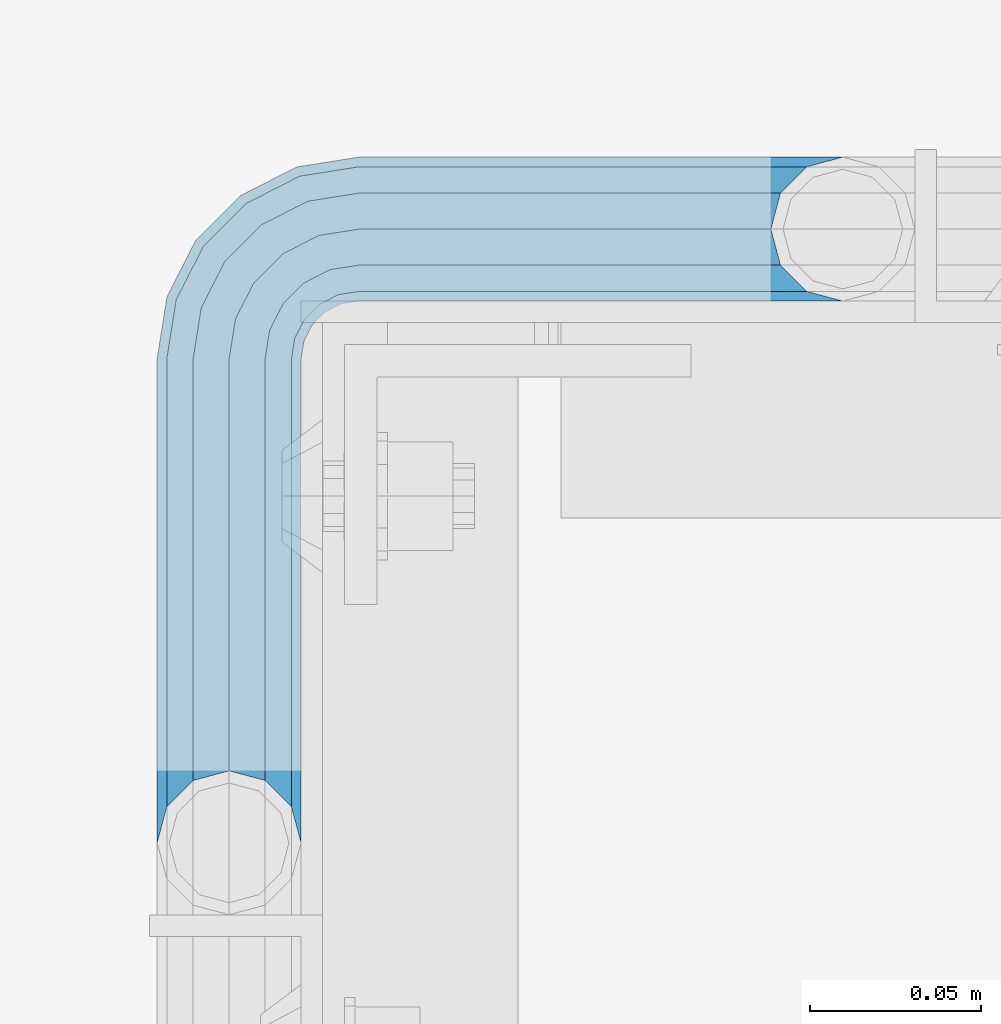
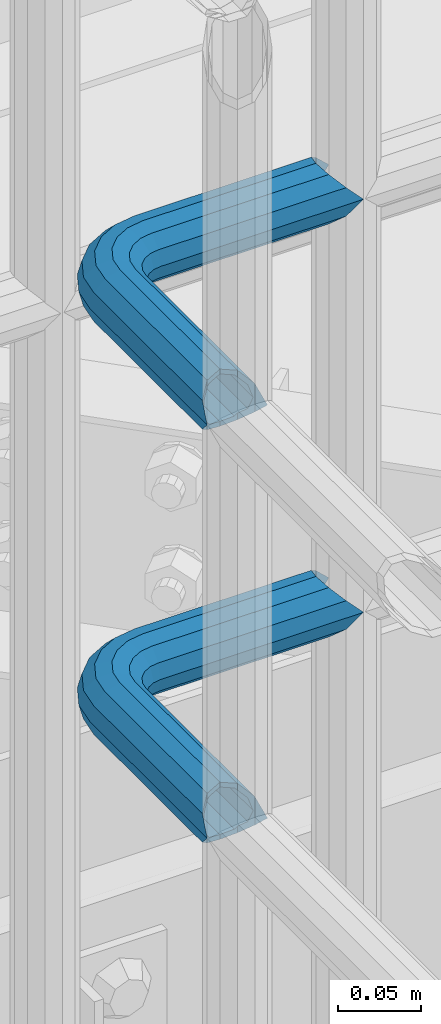
# One storey, part 1109 of 1876: 2 beams, 1 element without a shape of its own.
"""IFC2X3 building model written with IfcOpenShell, lengths in millimetres."""

from ifc_helpers import new_model, si_unit, frame, origin_with_axes, place, context, subcontext, project, spatial, faceted_brep, material, type_object, element, aggregate, save


model = new_model("IFC2X3")

# Units and contexts
model_context = context("Model", 3, precision=1e-05, world=origin_with_axes())
body_context = subcontext(model_context, "Body", "Model", "MODEL_VIEW")
ifc_project = project(units=[si_unit("LENGTHUNIT", "METRE", prefix="MILLI"), si_unit("AREAUNIT", "SQUARE_METRE"), si_unit("VOLUMEUNIT", "CUBIC_METRE"), si_unit("MASSUNIT", "GRAM", prefix="KILO"), si_unit("TIMEUNIT", "SECOND"), si_unit("PLANEANGLEUNIT", "RADIAN"), si_unit("SOLIDANGLEUNIT", "STERADIAN"), si_unit("THERMODYNAMICTEMPERATUREUNIT", "DEGREE_CELSIUS"), si_unit("LUMINOUSINTENSITYUNIT", "LUMEN")], contexts=[model_context])

# Site, building, storey
site_placement = place(None, origin_with_axes())
site = spatial("IfcSite", under=ifc_project, at=site_placement, CompositionType="ELEMENT")
building_placement = place(site_placement, origin_with_axes())
building = spatial("IfcBuilding", under=site, at=building_placement, Name="Undefined", CompositionType="ELEMENT")
storey_placement = place(building_placement, origin_with_axes())
storey = spatial("IfcBuildingStorey", under=building, at=storey_placement, Name="Undefined", CompositionType="ELEMENT", Elevation=0.0)

# Assembly, beams
assembly_placement = place(storey_placement, origin_with_axes())
assembly = element("IfcElementAssembly", 1, at=assembly_placement, inside=storey, Name="HANDRAIL", AssemblyPlace="NOTDEFINED", PredefinedType="RIGID_FRAME")
ifc_material = material()
beam_type = type_object("IfcBeamType", Name="PIPE1-1/4STD", PredefinedType="NOTDEFINED")
beam_1_placement = place(assembly_placement, frame((3517.90143150121, -11745.4324531238, 8480.425), z_axis=(0.0, 0.0, -1.0), x_axis=(-1.0, 0.0, 0.0)))
beam_1 = element("IfcBeam", 2, at=beam_1_placement, type_object=beam_type, material=ifc_material, Name="HANDRAIL", ObjectType="PIPE1-1/4STD", context=body_context, shape_type="Brep", body=[
    faceted_brep([(9.09494701772928e-13, 21.0820000000003, 0.0), (10.5409999957128, 18.2575475579433, -10.5409999999993), (10.5409999999983, 18.2575475625836, 10.5410000000011), (10.5409999999983, -18.2575475625836, 10.5410000000011), (10.5409999957128, -18.2575475672238, -10.5409999999993), (9.09494701772928e-13, -21.0820000000003, 0.0), (18.2575475625817, -10.5410000000011, 18.2575475625836), (18.2575475625817, -10.5409999999974, 13.3999612267289), (13.6205863358537, -15.1779612267255, 8.76300000000083), (11.2725475625793, -17.5259999999998, 0.0), (13.6205863358537, -15.1779612267255, -8.76299999999901), (18.2575475625817, -10.5409999999974, -13.3999612267271), (18.2575475625817, -10.5410000000011, -18.2575475625836), (21.0819999999985, 0.0, -17.5259999999998), (21.0819999999985, 0.0, -21.0819999999985), (18.7339612267233, -8.76300000000083, -15.1779612267255), (18.7339612267251, 8.76299999999901, -15.1779612267255), (18.2575475625817, 10.5410000000011, -13.3999612267235), (18.2575475625817, 10.5409999999993, -18.2575475625836), (13.6205863358573, 15.1779612267255, -8.76299999999901), (11.2725475625839, 17.5259999999998, 0.0), (13.6205863358573, 15.1779612267255, 8.76300000000083), (18.2575475625817, 10.5410000000011, 13.3999612267253), (18.2575475625817, 10.5409999999993, 18.2575475625836), (18.7339612267251, 8.76299999999901, 15.1779612267273), (21.0819999999985, 1.81898940354586e-12, 17.5259999999998), (21.0819999999985, 1.81898940354586e-12, 21.0820000000003), (18.7339612267233, -8.76300000000083, 15.1779612267273), (141.7320022583, -8.7629999999981, 15.1779612267255), (141.7320022583, 1.81898940354586e-12, 17.525999999998), (153.505549272468, -1.86474665447258, 17.525999999998), (150.797633350759, -10.1988549067664, 15.1779612267237), (141.7320022583, -15.1779612267246, 8.76299999999901), (148.815301313444, -16.2998455832249, 8.76299999999901), (141.732002258301, -17.5259999999989, -1.81898940354586e-12), (148.08971742905, -18.5329631590612, -1.81898940354586e-12), (141.7320022583, -15.1779612267246, -8.76300000000083), (148.815301313443, -16.2998455832249, -8.76300000000083), (141.7320022583, -8.76299999999901, -15.1779612267273), (150.797633350759, -10.1988549067664, -15.1779612267273), (141.7320022583, 1.81898940354586e-12, -17.5260000000017), (153.505549272467, -1.86474665447258, -17.5260000000017), (141.7320022583, 8.76300000000174, -15.1779612267273), (156.213465194176, 6.46936159782217, -15.1779612267273), (141.7320022583, 15.1779612267273, -8.76300000000083), (158.195797231491, 12.5703522742806, -8.76300000000083), (141.7320022583, 17.5260000000017, -1.81898940354586e-12), (158.921381115884, 14.803469850116, -1.81898940354586e-12), (141.7320022583, 15.1779612267273, 8.76299999999901), (158.195797231491, 12.5703522742806, 8.76299999999901), (141.7320022583, 8.76300000000174, 15.1779612267255), (156.213465194176, 6.46936159782217, 15.1779612267237), (179.832000732422, -38.0999984741202, -17.5260000000017), (171.069000732422, -38.0999984741202, -15.1779612267273), (171.069000732422, -161.097989750122, -15.1779612267255), (179.832000732422, -158.7499511731, -17.5259999999998), (188.595000732423, -38.0999984741202, -15.1779612267273), (188.595000732422, -161.097990142627, -15.1779612267255), (169.291000732422, -38.0999984741202, -18.2575475625854), (179.832000732422, -38.0999984741202, -21.0820000000003), (179.832000732422, -158.7499511731, -21.0820000000003), (169.291000732422, -161.574403610517, -18.2575475625836), (161.574453169838, -38.0999984741193, -10.5410000000011), (161.574453169838, -169.2909511731, -10.5409999999993), (158.750000732422, -38.0999984741193, -1.81898940354586e-12), (158.750000732422, -179.831954956055, 0.0), (161.574453169838, -169.2909511731, 10.5409999999993), (161.574453169839, -38.0999984741193, 10.5409999999993), (169.291000732423, -38.0999984741193, 18.2575475625817), (169.291000732422, -161.574403610517, 18.2575475625836), (179.832000732423, -38.0999984741193, 21.0819999999985), (179.832000732422, -158.7499511731, 21.0820000000003), (141.7320022583, 10.5410000000011, 18.2575475625817), (141.7320022583, 18.2575475625854, 10.5409999999993), (141.7320022583, 21.0820000000012, -1.81898940354586e-12), (141.7320022583, 18.2575475625854, -10.5410000000011), (141.7320022583, 10.5410000000011, -18.2575475625854), (141.7320022583, 1.81898940354586e-12, -21.0820000000022), (141.7320022583, -10.5409999999983, -18.2575475625854), (141.7320022583, -18.2575475625817, -10.5410000000011), (141.732002258301, -21.0819999999985, -1.81898940354586e-12), (141.7320022583, -18.2575475625817, 10.5409999999993), (141.7320022583, -10.5409999999983, 18.2575475625817), (141.7320022583, 1.81898940354586e-12, 21.0819999999985), (153.505549272468, -1.86474665447258, 21.0819999999985), (156.762897410175, 8.16034008379484, 18.2575475625817), (159.147441744916, 15.4992129264911, 10.5409999999993), (160.020245547882, 18.1854268220623, -1.81898940354586e-12), (159.147441744916, 15.4992129264911, -10.5410000000011), (156.762897410174, 8.16034008379484, -18.2575475625854), (153.505549272467, -1.86474665447258, -21.0820000000022), (150.24820113476, -11.8898333927391, -18.2575475625854), (147.863656800018, -19.2287062354353, -10.5410000000011), (146.990852997053, -21.9149201310065, -1.81898940354586e-12), (147.863656800019, -19.2287062354362, 10.5409999999993), (150.248201134761, -11.8898333927391, 18.2575475625817), (157.930775129339, -15.8043003606008, 18.2575475625817), (164.126619473753, -7.27645222289357, 21.0819999999985), (153.395102273439, -22.0471184766338, 10.5409999999993), (151.734930784924, -24.332148498308, -1.81898940354586e-12), (153.395102273439, -22.0471184766338, -10.5410000000011), (157.930775129338, -15.8043003606008, -18.2575475625854), (164.126619473752, -7.27645222289357, -21.0820000000022), (170.322463818167, 1.25139591481275, -18.2575475625854), (174.858136674066, 7.49421403084671, -10.5410000000011), (176.518308162581, 9.77924405251997, -1.81898940354586e-12), (174.858136674067, 7.49421403084671, 10.5409999999993), (170.322463818167, 1.25139591481275, 18.2575475625817), (172.555548509522, -15.7053812586619, 21.0819999999985), (181.083396647228, -9.50953691424547, 18.2575475625817), (164.027700371817, -21.9012256030774, 18.2575475625817), (157.784882255784, -26.4368984589782, 10.5409999999993), (155.499852234111, -28.0970699474938, -1.81898940354586e-12), (157.784882255784, -26.4368984589782, -10.5410000000011), (164.027700371817, -21.9012256030774, -18.2575475625854), (172.555548509522, -15.7053812586619, -21.0820000000022), (181.083396647228, -9.50953691424547, -18.2575475625854), (187.32621476326, -4.97386405834459, -10.5410000000011), (189.611244784934, -3.31369256982998, -1.81898940354586e-12), (187.32621476326, -4.97386405834459, 10.5409999999993), (187.992340816218, -23.0691033222502, 18.2575475625817), (195.331213658914, -20.6845589875093, 10.5409999999993), (177.96725407795, -26.3264514599559, 21.0819999999985), (167.942167339683, -29.5837995976626, 18.2575475625817), (160.603294496986, -31.9683439324035, 10.5409999999993), (157.917080601415, -32.8411477353693, -1.81898940354586e-12), (160.603294496986, -31.9683439324035, -10.5410000000011), (167.942167339682, -29.5837995976635, -18.2575475625854), (177.96725407795, -26.3264514599568, -21.0820000000022), (187.992340816217, -23.0691033222511, -18.2575475625854), (195.331213658914, -20.6845589875093, -10.5410000000011), (198.017427554485, -19.8117551845444, -1.81898940354586e-12), (198.089548295007, -38.0999984741193, 10.5409999999993), (200.914000732423, -38.0999984741202, -1.81898940354586e-12), (190.373000732423, -38.0999984741193, 18.2575475625817), (190.373000732422, -38.0999984741202, -18.2575475625854), (198.089548295006, -38.0999984741202, -10.5410000000011), (200.913999999997, -179.831951173101, 0.0), (198.089548295005, -169.2909511731, -10.5409999999993), (190.373000732422, -161.574403610517, -18.2575475625836), (190.372999999998, -161.574403610517, -13.3999619591505), (169.290999999997, -161.574403610517, -13.3999604943019), (164.654039505696, -38.0999984741193, -8.76300000000083), (164.654039505696, -166.211364104819, -8.76300000000083), (162.306000732422, -38.0999984741193, -1.81898940354586e-12), (162.306000732422, -168.559402878092, 0.0), (164.654039505696, -166.211364104819, 8.76299999999901), (169.290999999997, -161.574403610517, 13.3999604943019), (164.654039505696, -38.0999984741193, 8.76299999999901), (171.069000732422, -38.0999984741193, 15.1779612267255), (171.069000732422, -161.097989750122, 15.1779612267255), (179.832000732422, -158.7499511731, 17.5259999999998), (179.832000732423, -38.0999984741193, 17.525999999998), (188.595000732423, -38.0999984741193, 15.1779612267255), (188.595000732422, -161.097990142627, 15.1779612267255), (197.358000732423, -38.0999984741202, -1.81898940354586e-12), (195.009961959149, -38.0999984741202, -8.76300000000083), (195.009961959148, -166.211365569668, -8.76300000000083), (197.358000732422, -168.559404342942, 0.0), (195.009961959149, -38.0999984741193, 8.76299999999901), (195.009961959148, -166.211365569668, 8.76299999999901), (190.372999999998, -161.574403610517, 13.3999619591505), (190.373000732422, -161.574403610517, 18.2575475625836), (198.089548295005, -169.2909511731, 10.5409999999993), (186.301362330245, -23.6185355382495, -15.1779612267273), (192.402353006703, -21.6362035009342, -8.76300000000083), (177.96725407795, -26.3264514599568, -17.5260000000017), (169.633145825655, -29.0343673816642, -15.1779612267273), (163.532155149196, -31.0166994189794, -8.76300000000083), (161.299037573361, -31.7422833033716, -1.81898940354586e-12), (163.532155149197, -31.0166994189785, 8.76299999999901), (169.633145825655, -29.0343673816642, 15.1779612267255), (177.96725407795, -26.3264514599568, 17.525999999998), (186.301362330245, -23.6185355382486, 15.1779612267255), (192.402353006703, -21.6362035009342, 8.76299999999901), (194.635470582539, -20.9106196165412, -1.81898940354586e-12), (184.834777081907, -6.78399948972401, -8.76300000000083), (186.734380352937, -5.40385692698237, -1.81898940354586e-12), (179.644964431229, -10.5546190928217, -15.1779612267273), (172.555548509522, -15.7053812586619, -17.5260000000017), (165.466132587815, -20.8561434245012, -15.1779612267273), (160.276319937137, -24.6267630275997, -8.76300000000083), (158.376716666108, -26.0069055903414, -1.81898940354586e-12), (160.276319937138, -24.6267630275997, 8.76299999999901), (165.466132587815, -20.8561434245012, 15.1779612267237), (172.555548509522, -15.7053812586619, 17.525999999998), (179.64496443123, -10.5546190928217, 15.1779612267237), (184.834777081907, -6.7839994897231, 8.76299999999901), (174.428143805429, 6.90237962052288, -1.81898940354586e-12), (173.048001242688, 5.00277634949271, 8.76299999999901), (173.048001242688, 5.00277634949271, -8.76300000000083), (169.277381639591, -0.187036301185799, -15.1779612267273), (164.126619473753, -7.27645222289357, -17.5260000000017), (158.975857307914, -14.3658681446022, -15.1779612267273), (155.205237704817, -19.5556807952798, -8.76300000000083), (153.825095142076, -21.45528406631, -1.81898940354586e-12), (155.205237704817, -19.5556807952798, 8.76299999999901), (158.975857307914, -14.3658681446022, 15.1779612267237), (164.126619473753, -7.27645222289357, 17.525999999998), (169.277381639591, -0.187036301185799, 15.1779612267237)], [[[0, 1, 2]], [[3, 4, 5]], [[6, 7, 8, 9, 10, 11, 12, 4, 3]], [[13, 14, 12, 11, 15]], [[16, 17, 18, 14, 13]], [[2, 1, 18, 17, 19, 20, 21, 22, 23]], [[23, 22, 24, 25, 26]], [[26, 25, 27, 7, 6]], [[28, 29, 30, 31]], [[32, 28, 31, 33]], [[34, 32, 33, 35]], [[36, 34, 35, 37]], [[38, 36, 37, 39]], [[40, 38, 39, 41]], [[42, 40, 41, 43]], [[44, 42, 43, 45]], [[46, 44, 45, 47]], [[48, 46, 47, 49]], [[50, 48, 49, 51]], [[52, 53, 54, 55]], [[56, 52, 55, 57]], [[58, 59, 60, 61]], [[62, 58, 61, 63]], [[64, 62, 63, 65]], [[65, 63, 66]], [[67, 64, 65, 66]], [[68, 67, 66, 69]], [[70, 68, 69, 71]], [[72, 73, 2, 23]], [[73, 74, 0, 2]], [[74, 75, 1, 0]], [[75, 76, 18, 1]], [[76, 77, 14, 18]], [[77, 78, 12, 14]], [[78, 79, 4, 12]], [[79, 80, 5, 4]], [[80, 81, 3, 5]], [[81, 82, 6, 3]], [[82, 83, 26, 6]], [[83, 72, 23, 26]], [[72, 83, 84, 85]], [[73, 72, 85, 86]], [[74, 73, 86, 87]], [[75, 74, 87, 88]], [[76, 75, 88, 89]], [[77, 76, 89, 90]], [[78, 77, 90, 91]], [[79, 78, 91, 92]], [[80, 79, 92, 93]], [[81, 80, 93, 94]], [[82, 81, 94, 95]], [[83, 82, 95, 84]], [[95, 96, 97, 84]], [[94, 98, 96, 95]], [[93, 99, 98, 94]], [[92, 100, 99, 93]], [[91, 101, 100, 92]], [[90, 102, 101, 91]], [[89, 103, 102, 90]], [[88, 104, 103, 89]], [[87, 105, 104, 88]], [[86, 106, 105, 87]], [[85, 107, 106, 86]], [[84, 97, 107, 85]], [[97, 108, 109, 107]], [[96, 110, 108, 97]], [[98, 111, 110, 96]], [[99, 112, 111, 98]], [[100, 113, 112, 99]], [[101, 114, 113, 100]], [[102, 115, 114, 101]], [[103, 116, 115, 102]], [[104, 117, 116, 103]], [[105, 118, 117, 104]], [[106, 119, 118, 105]], [[107, 109, 119, 106]], [[109, 120, 121, 119]], [[108, 122, 120, 109]], [[110, 123, 122, 108]], [[111, 124, 123, 110]], [[112, 125, 124, 111]], [[113, 126, 125, 112]], [[114, 127, 126, 113]], [[115, 128, 127, 114]], [[116, 129, 128, 115]], [[117, 130, 129, 116]], [[118, 131, 130, 117]], [[119, 121, 131, 118]], [[121, 132, 133, 131]], [[120, 134, 132, 121]], [[122, 70, 134, 120]], [[123, 68, 70, 122]], [[124, 67, 68, 123]], [[125, 64, 67, 124]], [[126, 62, 64, 125]], [[127, 58, 62, 126]], [[128, 59, 58, 127]], [[129, 135, 59, 128]], [[130, 136, 135, 129]], [[131, 133, 136, 130]], [[136, 133, 137, 138]], [[135, 136, 138, 139]], [[59, 135, 139, 60]], [[57, 55, 60, 139, 140]], [[54, 141, 61, 60, 55]], [[53, 142, 143, 141, 54]], [[142, 144, 145, 143]], [[66, 63, 61, 141, 143, 145, 146, 147, 69]], [[144, 148, 146, 145]], [[146, 148, 149, 150, 147]], [[69, 147, 150, 151, 71]], [[149, 152, 151, 150]], [[152, 153, 154, 151]], [[155, 156, 157, 158]], [[159, 155, 158, 160]], [[154, 153, 159, 160, 161]], [[71, 151, 154, 161, 162]], [[134, 70, 71, 162]], [[132, 134, 162, 163]], [[133, 132, 163, 137]], [[137, 163, 138]], [[162, 161, 160, 158, 157, 140, 139, 138, 163]], [[156, 56, 57, 140, 157]], [[164, 56, 156, 165]], [[166, 52, 56, 164]], [[167, 53, 52, 166]], [[168, 142, 53, 167]], [[169, 144, 142, 168]], [[170, 148, 144, 169]], [[171, 149, 148, 170]], [[172, 152, 149, 171]], [[173, 153, 152, 172]], [[174, 159, 153, 173]], [[175, 155, 159, 174]], [[165, 156, 155, 175]], [[176, 165, 175, 177]], [[178, 164, 165, 176]], [[179, 166, 164, 178]], [[180, 167, 166, 179]], [[181, 168, 167, 180]], [[182, 169, 168, 181]], [[183, 170, 169, 182]], [[184, 171, 170, 183]], [[185, 172, 171, 184]], [[186, 173, 172, 185]], [[187, 174, 173, 186]], [[177, 175, 174, 187]], [[188, 177, 187, 189]], [[190, 176, 177, 188]], [[191, 178, 176, 190]], [[192, 179, 178, 191]], [[193, 180, 179, 192]], [[194, 181, 180, 193]], [[195, 182, 181, 194]], [[196, 183, 182, 195]], [[197, 184, 183, 196]], [[198, 185, 184, 197]], [[199, 186, 185, 198]], [[189, 187, 186, 199]], [[49, 189, 199, 51]], [[47, 188, 189, 49]], [[45, 190, 188, 47]], [[43, 191, 190, 45]], [[41, 192, 191, 43]], [[39, 193, 192, 41]], [[37, 194, 193, 39]], [[35, 195, 194, 37]], [[33, 196, 195, 35]], [[31, 197, 196, 33]], [[30, 198, 197, 31]], [[51, 199, 198, 30]], [[29, 50, 51, 30]], [[50, 29, 25, 24]], [[21, 48, 50, 24, 22]], [[46, 48, 21, 20]], [[44, 46, 20, 19]], [[42, 44, 19, 17, 16]], [[40, 42, 16, 13]], [[38, 40, 13, 15]], [[10, 36, 38, 15, 11]], [[34, 36, 10, 9]], [[32, 34, 9, 8]], [[28, 32, 8, 7, 27]], [[29, 28, 27, 25]]]),
])
beam_2_placement = place(assembly_placement, frame((3517.90143150121, -11745.4324531238, 8785.225), z_axis=(0.0, 0.0, -1.0), x_axis=(-1.0, 0.0, 0.0)))
beam_2 = element("IfcBeam", 3, at=beam_2_placement, type_object=beam_type, material=ifc_material, Name="HANDRAIL", ObjectType="PIPE1-1/4STD", context=body_context, shape_type="Brep", body=[
    faceted_brep([(9.09494701772928e-13, 21.0820000000003, 0.0), (10.5409999957128, 18.2575475579433, -10.5409999999993), (10.5409999999983, 18.2575475625836, 10.5410000000011), (10.5409999999983, -18.2575475625836, 10.5410000000011), (10.5409999957128, -18.2575475672238, -10.5409999999993), (9.09494701772928e-13, -21.0820000000003, 0.0), (18.2575475625817, -10.5410000000011, 18.2575475625836), (18.2575475625817, -10.5409999999974, 13.3999612267289), (13.6205863358537, -15.1779612267255, 8.76300000000083), (11.2725475625793, -17.5259999999998, 0.0), (13.6205863358537, -15.1779612267255, -8.76299999999901), (18.2575475625817, -10.5409999999974, -13.3999612267271), (18.2575475625817, -10.5410000000011, -18.2575475625836), (21.0819999999985, 0.0, -17.5259999999998), (21.0819999999985, 0.0, -21.0819999999985), (18.7339612267233, -8.76300000000083, -15.1779612267255), (18.7339612267251, 8.76299999999901, -15.1779612267255), (18.2575475625817, 10.5410000000011, -13.3999612267235), (18.2575475625817, 10.5409999999993, -18.2575475625836), (13.6205863358573, 15.1779612267255, -8.76299999999901), (11.2725475625839, 17.5259999999998, 0.0), (13.6205863358573, 15.1779612267255, 8.76300000000083), (18.2575475625817, 10.5410000000011, 13.3999612267253), (18.2575475625817, 10.5409999999993, 18.2575475625836), (18.7339612267251, 8.76299999999901, 15.1779612267273), (21.0819999999985, 1.81898940354586e-12, 17.5259999999998), (21.0819999999985, 1.81898940354586e-12, 21.0820000000003), (18.7339612267233, -8.76300000000083, 15.1779612267273), (141.7320022583, -8.7629999999981, 15.1779612267255), (141.7320022583, 1.81898940354586e-12, 17.525999999998), (153.505549272468, -1.86474665447258, 17.525999999998), (150.797633350759, -10.1988549067664, 15.1779612267237), (141.7320022583, -15.1779612267246, 8.76299999999901), (148.815301313444, -16.2998455832249, 8.76299999999901), (141.732002258301, -17.5259999999989, -1.81898940354586e-12), (148.08971742905, -18.5329631590612, -1.81898940354586e-12), (141.7320022583, -15.1779612267246, -8.76300000000083), (148.815301313443, -16.2998455832249, -8.76300000000083), (141.7320022583, -8.76299999999901, -15.1779612267273), (150.797633350759, -10.1988549067664, -15.1779612267273), (141.7320022583, 1.81898940354586e-12, -17.5260000000017), (153.505549272467, -1.86474665447258, -17.5260000000017), (141.7320022583, 8.76300000000174, -15.1779612267273), (156.213465194176, 6.46936159782217, -15.1779612267273), (141.7320022583, 15.1779612267273, -8.76300000000083), (158.195797231491, 12.5703522742806, -8.76300000000083), (141.7320022583, 17.5260000000017, -1.81898940354586e-12), (158.921381115884, 14.803469850116, -1.81898940354586e-12), (141.7320022583, 15.1779612267273, 8.76299999999901), (158.195797231491, 12.5703522742806, 8.76299999999901), (141.7320022583, 8.76300000000174, 15.1779612267255), (156.213465194176, 6.46936159782217, 15.1779612267237), (179.832000732422, -38.0999984741202, -17.5260000000017), (171.069000732422, -38.0999984741202, -15.1779612267273), (171.069000732422, -161.097989750122, -15.1779612267255), (179.832000732422, -158.7499511731, -17.5259999999998), (188.595000732423, -38.0999984741202, -15.1779612267273), (188.595000732422, -161.097990142627, -15.1779612267255), (169.291000732422, -38.0999984741202, -18.2575475625854), (179.832000732422, -38.0999984741202, -21.0820000000003), (179.832000732422, -158.7499511731, -21.0820000000003), (169.291000732422, -161.574403610517, -18.2575475625836), (161.574453169838, -38.0999984741193, -10.5410000000011), (161.574453169838, -169.2909511731, -10.5409999999993), (158.750000732422, -38.0999984741193, -1.81898940354586e-12), (158.750000732422, -179.831954956055, 0.0), (161.574453169838, -169.2909511731, 10.5409999999993), (161.574453169839, -38.0999984741193, 10.5409999999993), (169.291000732423, -38.0999984741193, 18.2575475625817), (169.291000732422, -161.574403610517, 18.2575475625836), (179.832000732423, -38.0999984741193, 21.0819999999985), (179.832000732422, -158.7499511731, 21.0820000000003), (141.7320022583, 10.5410000000011, 18.2575475625817), (141.7320022583, 18.2575475625854, 10.5409999999993), (141.7320022583, 21.0820000000012, -1.81898940354586e-12), (141.7320022583, 18.2575475625854, -10.5410000000011), (141.7320022583, 10.5410000000011, -18.2575475625854), (141.7320022583, 1.81898940354586e-12, -21.0820000000022), (141.7320022583, -10.5409999999983, -18.2575475625854), (141.7320022583, -18.2575475625817, -10.5410000000011), (141.732002258301, -21.0819999999985, -1.81898940354586e-12), (141.7320022583, -18.2575475625817, 10.5409999999993), (141.7320022583, -10.5409999999983, 18.2575475625817), (141.7320022583, 1.81898940354586e-12, 21.0819999999985), (153.505549272468, -1.86474665447258, 21.0819999999985), (156.762897410175, 8.16034008379484, 18.2575475625817), (159.147441744916, 15.4992129264911, 10.5409999999993), (160.020245547882, 18.1854268220623, -1.81898940354586e-12), (159.147441744916, 15.4992129264911, -10.5410000000011), (156.762897410174, 8.16034008379484, -18.2575475625854), (153.505549272467, -1.86474665447258, -21.0820000000022), (150.24820113476, -11.8898333927391, -18.2575475625854), (147.863656800018, -19.2287062354353, -10.5410000000011), (146.990852997053, -21.9149201310065, -1.81898940354586e-12), (147.863656800019, -19.2287062354362, 10.5409999999993), (150.248201134761, -11.8898333927391, 18.2575475625817), (157.930775129339, -15.8043003606008, 18.2575475625817), (164.126619473753, -7.27645222289357, 21.0819999999985), (153.395102273439, -22.0471184766338, 10.5409999999993), (151.734930784924, -24.332148498308, -1.81898940354586e-12), (153.395102273439, -22.0471184766338, -10.5410000000011), (157.930775129338, -15.8043003606008, -18.2575475625854), (164.126619473752, -7.27645222289357, -21.0820000000022), (170.322463818167, 1.25139591481275, -18.2575475625854), (174.858136674066, 7.49421403084671, -10.5410000000011), (176.518308162581, 9.77924405251997, -1.81898940354586e-12), (174.858136674067, 7.49421403084671, 10.5409999999993), (170.322463818167, 1.25139591481275, 18.2575475625817), (172.555548509522, -15.7053812586619, 21.0819999999985), (181.083396647228, -9.50953691424547, 18.2575475625817), (164.027700371817, -21.9012256030774, 18.2575475625817), (157.784882255784, -26.4368984589782, 10.5409999999993), (155.499852234111, -28.0970699474938, -1.81898940354586e-12), (157.784882255784, -26.4368984589782, -10.5410000000011), (164.027700371817, -21.9012256030774, -18.2575475625854), (172.555548509522, -15.7053812586619, -21.0820000000022), (181.083396647228, -9.50953691424547, -18.2575475625854), (187.32621476326, -4.97386405834459, -10.5410000000011), (189.611244784934, -3.31369256982998, -1.81898940354586e-12), (187.32621476326, -4.97386405834459, 10.5409999999993), (187.992340816218, -23.0691033222502, 18.2575475625817), (195.331213658914, -20.6845589875093, 10.5409999999993), (177.96725407795, -26.3264514599559, 21.0819999999985), (167.942167339683, -29.5837995976626, 18.2575475625817), (160.603294496986, -31.9683439324035, 10.5409999999993), (157.917080601415, -32.8411477353693, -1.81898940354586e-12), (160.603294496986, -31.9683439324035, -10.5410000000011), (167.942167339682, -29.5837995976635, -18.2575475625854), (177.96725407795, -26.3264514599568, -21.0820000000022), (187.992340816217, -23.0691033222511, -18.2575475625854), (195.331213658914, -20.6845589875093, -10.5410000000011), (198.017427554485, -19.8117551845444, -1.81898940354586e-12), (198.089548295007, -38.0999984741193, 10.5409999999993), (200.914000732423, -38.0999984741202, -1.81898940354586e-12), (190.373000732423, -38.0999984741193, 18.2575475625817), (190.373000732422, -38.0999984741202, -18.2575475625854), (198.089548295006, -38.0999984741202, -10.5410000000011), (200.913999999997, -179.831951173101, 0.0), (198.089548295005, -169.2909511731, -10.5409999999993), (190.373000732422, -161.574403610517, -18.2575475625836), (190.372999999998, -161.574403610517, -13.3999619591505), (169.290999999997, -161.574403610517, -13.3999604943019), (164.654039505696, -38.0999984741193, -8.76300000000083), (164.654039505696, -166.211364104819, -8.76300000000083), (162.306000732422, -38.0999984741193, -1.81898940354586e-12), (162.306000732422, -168.559402878092, 0.0), (164.654039505696, -166.211364104819, 8.76299999999901), (169.290999999997, -161.574403610517, 13.3999604943019), (164.654039505696, -38.0999984741193, 8.76299999999901), (171.069000732422, -38.0999984741193, 15.1779612267255), (171.069000732422, -161.097989750122, 15.1779612267255), (179.832000732422, -158.7499511731, 17.5259999999998), (179.832000732423, -38.0999984741193, 17.525999999998), (188.595000732423, -38.0999984741193, 15.1779612267255), (188.595000732422, -161.097990142627, 15.1779612267255), (197.358000732423, -38.0999984741202, -1.81898940354586e-12), (195.009961959149, -38.0999984741202, -8.76300000000083), (195.009961959148, -166.211365569668, -8.76300000000083), (197.358000732422, -168.559404342942, 0.0), (195.009961959149, -38.0999984741193, 8.76299999999901), (195.009961959148, -166.211365569668, 8.76299999999901), (190.372999999998, -161.574403610517, 13.3999619591505), (190.373000732422, -161.574403610517, 18.2575475625836), (198.089548295005, -169.2909511731, 10.5409999999993), (186.301362330245, -23.6185355382495, -15.1779612267273), (192.402353006703, -21.6362035009342, -8.76300000000083), (177.96725407795, -26.3264514599568, -17.5260000000017), (169.633145825655, -29.0343673816642, -15.1779612267273), (163.532155149196, -31.0166994189794, -8.76300000000083), (161.299037573361, -31.7422833033716, -1.81898940354586e-12), (163.532155149197, -31.0166994189785, 8.76299999999901), (169.633145825655, -29.0343673816642, 15.1779612267255), (177.96725407795, -26.3264514599568, 17.525999999998), (186.301362330245, -23.6185355382486, 15.1779612267255), (192.402353006703, -21.6362035009342, 8.76299999999901), (194.635470582539, -20.9106196165412, -1.81898940354586e-12), (184.834777081907, -6.78399948972401, -8.76300000000083), (186.734380352937, -5.40385692698237, -1.81898940354586e-12), (179.644964431229, -10.5546190928217, -15.1779612267273), (172.555548509522, -15.7053812586619, -17.5260000000017), (165.466132587815, -20.8561434245012, -15.1779612267273), (160.276319937137, -24.6267630275997, -8.76300000000083), (158.376716666108, -26.0069055903414, -1.81898940354586e-12), (160.276319937138, -24.6267630275997, 8.76299999999901), (165.466132587815, -20.8561434245012, 15.1779612267237), (172.555548509522, -15.7053812586619, 17.525999999998), (179.64496443123, -10.5546190928217, 15.1779612267237), (184.834777081907, -6.7839994897231, 8.76299999999901), (174.428143805429, 6.90237962052288, -1.81898940354586e-12), (173.048001242688, 5.00277634949271, 8.76299999999901), (173.048001242688, 5.00277634949271, -8.76300000000083), (169.277381639591, -0.187036301185799, -15.1779612267273), (164.126619473753, -7.27645222289357, -17.5260000000017), (158.975857307914, -14.3658681446022, -15.1779612267273), (155.205237704817, -19.5556807952798, -8.76300000000083), (153.825095142076, -21.45528406631, -1.81898940354586e-12), (155.205237704817, -19.5556807952798, 8.76299999999901), (158.975857307914, -14.3658681446022, 15.1779612267237), (164.126619473753, -7.27645222289357, 17.525999999998), (169.277381639591, -0.187036301185799, 15.1779612267237)], [[[0, 1, 2]], [[3, 4, 5]], [[6, 7, 8, 9, 10, 11, 12, 4, 3]], [[13, 14, 12, 11, 15]], [[16, 17, 18, 14, 13]], [[2, 1, 18, 17, 19, 20, 21, 22, 23]], [[23, 22, 24, 25, 26]], [[26, 25, 27, 7, 6]], [[28, 29, 30, 31]], [[32, 28, 31, 33]], [[34, 32, 33, 35]], [[36, 34, 35, 37]], [[38, 36, 37, 39]], [[40, 38, 39, 41]], [[42, 40, 41, 43]], [[44, 42, 43, 45]], [[46, 44, 45, 47]], [[48, 46, 47, 49]], [[50, 48, 49, 51]], [[52, 53, 54, 55]], [[56, 52, 55, 57]], [[58, 59, 60, 61]], [[62, 58, 61, 63]], [[64, 62, 63, 65]], [[65, 63, 66]], [[67, 64, 65, 66]], [[68, 67, 66, 69]], [[70, 68, 69, 71]], [[72, 73, 2, 23]], [[73, 74, 0, 2]], [[74, 75, 1, 0]], [[75, 76, 18, 1]], [[76, 77, 14, 18]], [[77, 78, 12, 14]], [[78, 79, 4, 12]], [[79, 80, 5, 4]], [[80, 81, 3, 5]], [[81, 82, 6, 3]], [[82, 83, 26, 6]], [[83, 72, 23, 26]], [[72, 83, 84, 85]], [[73, 72, 85, 86]], [[74, 73, 86, 87]], [[75, 74, 87, 88]], [[76, 75, 88, 89]], [[77, 76, 89, 90]], [[78, 77, 90, 91]], [[79, 78, 91, 92]], [[80, 79, 92, 93]], [[81, 80, 93, 94]], [[82, 81, 94, 95]], [[83, 82, 95, 84]], [[95, 96, 97, 84]], [[94, 98, 96, 95]], [[93, 99, 98, 94]], [[92, 100, 99, 93]], [[91, 101, 100, 92]], [[90, 102, 101, 91]], [[89, 103, 102, 90]], [[88, 104, 103, 89]], [[87, 105, 104, 88]], [[86, 106, 105, 87]], [[85, 107, 106, 86]], [[84, 97, 107, 85]], [[97, 108, 109, 107]], [[96, 110, 108, 97]], [[98, 111, 110, 96]], [[99, 112, 111, 98]], [[100, 113, 112, 99]], [[101, 114, 113, 100]], [[102, 115, 114, 101]], [[103, 116, 115, 102]], [[104, 117, 116, 103]], [[105, 118, 117, 104]], [[106, 119, 118, 105]], [[107, 109, 119, 106]], [[109, 120, 121, 119]], [[108, 122, 120, 109]], [[110, 123, 122, 108]], [[111, 124, 123, 110]], [[112, 125, 124, 111]], [[113, 126, 125, 112]], [[114, 127, 126, 113]], [[115, 128, 127, 114]], [[116, 129, 128, 115]], [[117, 130, 129, 116]], [[118, 131, 130, 117]], [[119, 121, 131, 118]], [[121, 132, 133, 131]], [[120, 134, 132, 121]], [[122, 70, 134, 120]], [[123, 68, 70, 122]], [[124, 67, 68, 123]], [[125, 64, 67, 124]], [[126, 62, 64, 125]], [[127, 58, 62, 126]], [[128, 59, 58, 127]], [[129, 135, 59, 128]], [[130, 136, 135, 129]], [[131, 133, 136, 130]], [[136, 133, 137, 138]], [[135, 136, 138, 139]], [[59, 135, 139, 60]], [[57, 55, 60, 139, 140]], [[54, 141, 61, 60, 55]], [[53, 142, 143, 141, 54]], [[142, 144, 145, 143]], [[66, 63, 61, 141, 143, 145, 146, 147, 69]], [[144, 148, 146, 145]], [[146, 148, 149, 150, 147]], [[69, 147, 150, 151, 71]], [[149, 152, 151, 150]], [[152, 153, 154, 151]], [[155, 156, 157, 158]], [[159, 155, 158, 160]], [[154, 153, 159, 160, 161]], [[71, 151, 154, 161, 162]], [[134, 70, 71, 162]], [[132, 134, 162, 163]], [[133, 132, 163, 137]], [[137, 163, 138]], [[162, 161, 160, 158, 157, 140, 139, 138, 163]], [[156, 56, 57, 140, 157]], [[164, 56, 156, 165]], [[166, 52, 56, 164]], [[167, 53, 52, 166]], [[168, 142, 53, 167]], [[169, 144, 142, 168]], [[170, 148, 144, 169]], [[171, 149, 148, 170]], [[172, 152, 149, 171]], [[173, 153, 152, 172]], [[174, 159, 153, 173]], [[175, 155, 159, 174]], [[165, 156, 155, 175]], [[176, 165, 175, 177]], [[178, 164, 165, 176]], [[179, 166, 164, 178]], [[180, 167, 166, 179]], [[181, 168, 167, 180]], [[182, 169, 168, 181]], [[183, 170, 169, 182]], [[184, 171, 170, 183]], [[185, 172, 171, 184]], [[186, 173, 172, 185]], [[187, 174, 173, 186]], [[177, 175, 174, 187]], [[188, 177, 187, 189]], [[190, 176, 177, 188]], [[191, 178, 176, 190]], [[192, 179, 178, 191]], [[193, 180, 179, 192]], [[194, 181, 180, 193]], [[195, 182, 181, 194]], [[196, 183, 182, 195]], [[197, 184, 183, 196]], [[198, 185, 184, 197]], [[199, 186, 185, 198]], [[189, 187, 186, 199]], [[49, 189, 199, 51]], [[47, 188, 189, 49]], [[45, 190, 188, 47]], [[43, 191, 190, 45]], [[41, 192, 191, 43]], [[39, 193, 192, 41]], [[37, 194, 193, 39]], [[35, 195, 194, 37]], [[33, 196, 195, 35]], [[31, 197, 196, 33]], [[30, 198, 197, 31]], [[51, 199, 198, 30]], [[29, 50, 51, 30]], [[50, 29, 25, 24]], [[21, 48, 50, 24, 22]], [[46, 48, 21, 20]], [[44, 46, 20, 19]], [[42, 44, 19, 17, 16]], [[40, 42, 16, 13]], [[38, 40, 13, 15]], [[10, 36, 38, 15, 11]], [[34, 36, 10, 9]], [[32, 34, 9, 8]], [[28, 32, 8, 7, 27]], [[29, 28, 27, 25]]]),
])
aggregate(assembly, [beam_1, beam_2])

save(model, "model.ifc")
